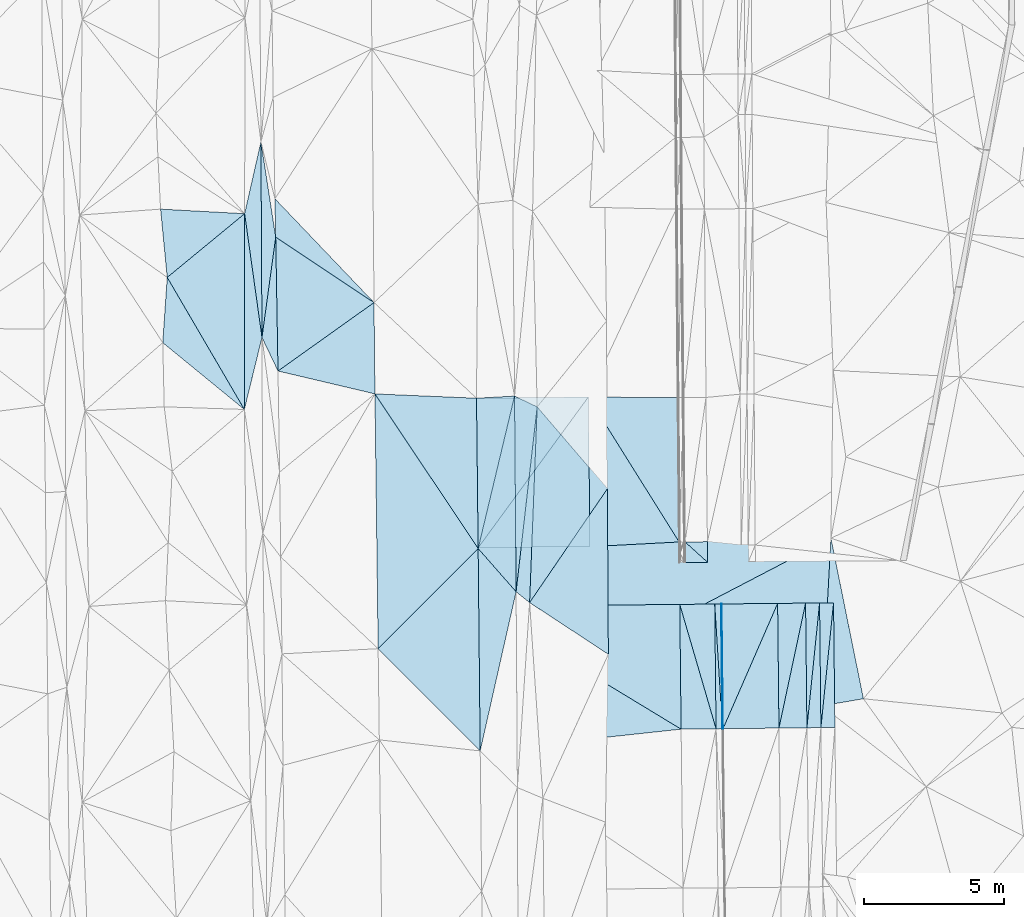
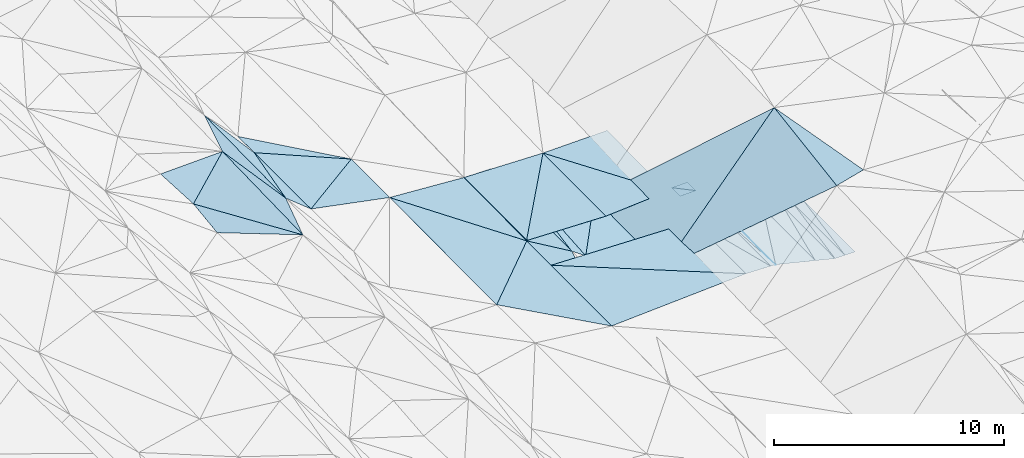
# One storey, part 36 of 275: 45 plates.
"""IFC2X3 building model written with IfcOpenShell, lengths in millimetres."""

from ifc_helpers import new_model, si_unit, frame, origin_with_axes, place, context, subcontext, project, spatial, polyline, outline, extrude, material, type_object, element, save


model = new_model("IFC2X3")

# Units and contexts
model_context = context("Model", 3, precision=1e-05, world=origin_with_axes())
body_context = subcontext(model_context, "Body", "Model", "MODEL_VIEW")
ifc_project = project(units=[si_unit("LENGTHUNIT", "METRE", prefix="MILLI"), si_unit("AREAUNIT", "SQUARE_METRE"), si_unit("VOLUMEUNIT", "CUBIC_METRE"), si_unit("MASSUNIT", "GRAM", prefix="KILO"), si_unit("TIMEUNIT", "SECOND"), si_unit("PLANEANGLEUNIT", "RADIAN"), si_unit("SOLIDANGLEUNIT", "STERADIAN"), si_unit("THERMODYNAMICTEMPERATUREUNIT", "DEGREE_CELSIUS"), si_unit("LUMINOUSINTENSITYUNIT", "LUMEN")], contexts=[model_context])

# Site, building, storey
site_placement = place(None, origin_with_axes())
site = spatial("IfcSite", under=ifc_project, at=site_placement, CompositionType="ELEMENT")
building_placement = place(site_placement, origin_with_axes())
building = spatial("IfcBuilding", under=site, at=building_placement, Name="Undefined", CompositionType="ELEMENT")
storey_placement = place(building_placement, origin_with_axes())
storey = spatial("IfcBuildingStorey", under=building, at=storey_placement, Name="Undefined", CompositionType="ELEMENT", Elevation=0.0)

# Plates
ifc_material = material()
plate_type_1 = type_object("IfcPlateType", PredefinedType="NOTDEFINED")
plate_1_placement = place(storey_placement, frame((-55777.1554334215, 17783.2295851217, 41273.1487418391), z_axis=(-0.0501446646772077, 0.0208601791780179, -0.998524093614707), x_axis=(-0.0106741270589884, 0.999713559361864, 0.021421069991057)))
element("IfcPlate", 1, at=plate_1_placement, inside=storey, type_object=plate_type_1, material=ifc_material, Name="00_PR", context=body_context, shape_type="SweptSolid", body=[
    extrude(outline(polyline([(0.0, 0.0), (4462.4755859375, -5.58065949007869e-09), (4462.4462890625, 20.0245208740234), (0.0, 0.0)])), frame((-8.85201319254618e-08, 2.18876761149539e-07, -0.5000001331573), z_axis=(0.0, 0.0, 1.0), x_axis=(1.0, 0.0, 0.0)), (0.0, 0.0, 1.0), 1.0),
])
plate_2_placement = place(storey_placement, frame((-55804.7899737754, 22244.6326134434, 41367.7397417833), z_axis=(-0.0501609440777703, 0.0208600609211892, -0.998523278420484), x_axis=(0.0106741250532589, -0.99971355781946, -0.0214211429738157)))
element("IfcPlate", 2, at=plate_2_placement, inside=storey, type_object=plate_type_1, material=ifc_material, Name="00_PR", context=body_context, shape_type="SweptSolid", body=[
    extrude(outline(polyline([(0.0, 0.0), (4462.4599609375, -2.99041857942939e-09), (4462.4462890625, 20.0245208740234), (0.0, 0.0)])), frame((-8.85201319254618e-08, 2.18876761149539e-07, -0.5000001331573), z_axis=(0.0, 0.0, 1.0), x_axis=(1.0, 0.0, 0.0)), (0.0, 0.0, 1.0), 1.0),
])
plate_type_2 = type_object("IfcPlateType", PredefinedType="NOTDEFINED")
plate_3_placement = place(storey_placement, frame((-72876.4648465357, 29201.440175099, 41922.5067376926), z_axis=(0.162034691991105, 0.0235866719560773, -0.986503131012459), x_axis=(0.00138285245792622, 0.999707884204713, 0.0241295250267475)))
element("IfcPlate", 3, at=plate_3_placement, inside=storey, type_object=plate_type_2, material=ifc_material, Name="00", context=body_context, shape_type="SweptSolid", body=[
    extrude(outline(polyline([(0.0, 0.0), (7003.86767578125, 1.18670868687332e-08), (2578.59887695313, 634.619445800781), (0.0, 0.0)])), frame((-8.85201319254618e-08, 2.18876761149539e-07, -0.5000001331573), z_axis=(0.0, 0.0, 1.0), x_axis=(1.0, 0.0, 0.0)), (0.0, 0.0, 1.0), 1.0),
])
plate_type_3 = type_object("IfcPlateType", PredefinedType="NOTDEFINED")
plate_4_placement = place(storey_placement, frame((-60573.8020393631, 29647.2975248427, 41682.6393767617), z_axis=(-0.0319265502433423, 0.0219599536153499, -0.999248945872234), x_axis=(-0.590092143941473, -0.807335138867878, 0.00111139900097563)))
element("IfcPlate", 4, at=plate_4_placement, inside=storey, type_object=plate_type_3, material=ifc_material, Name="00_PR", context=body_context, shape_type="SweptSolid", body=[
    extrude(outline(polyline([(0.0, 0.0), (6680.767578125, -8.60018189996481e-09), (2395.93823242188, 3206.45239257813), (0.0, 0.0)])), frame((-8.85201319254618e-08, 2.18876761149539e-07, -0.5000001331573), z_axis=(0.0, 0.0, 1.0), x_axis=(1.0, 0.0, 0.0)), (0.0, 0.0, 1.0), 1.0),
])
plate_type_4 = type_object("IfcPlateType", PredefinedType="NOTDEFINED")
plate_5_placement = place(storey_placement, frame((-64516.0709698577, 24253.6794883369, 41690.064400732), z_axis=(-0.032895759389629, 0.02266842670576, -0.999201687070666), x_axis=(0.590092143943861, 0.807335138866125, -0.00111139900671296)))
element("IfcPlate", 5, at=plate_5_placement, inside=storey, type_object=plate_type_4, material=ifc_material, Name="00_PR", context=body_context, shape_type="SweptSolid", body=[
    extrude(outline(polyline([(0.0, 0.0), (6680.767578125, -8.60018189996481e-09), (2393.00903320313, 3207.89916992188), (0.0, 0.0)])), frame((-8.85201319254618e-08, 2.18876761149539e-07, -0.5000001331573), z_axis=(0.0, 0.0, 1.0), x_axis=(1.0, 0.0, 0.0)), (0.0, 0.0, 1.0), 1.0),
])
plate_type_5 = type_object("IfcPlateType", PredefinedType="NOTDEFINED")
plate_6_placement = place(storey_placement, frame((-56317.310180276, 24471.5150313919, 41794.6452085543), z_axis=(0.0197854119140253, 0.0208739121605425, -0.999586323068952), x_axis=(0.00998879700031528, -0.999736259864483, -0.0206793289702882)))
element("IfcPlate", 6, at=plate_6_placement, inside=storey, type_object=plate_type_5, material=ifc_material, Name="00_PR", context=body_context, shape_type="SweptSolid", body=[
    extrude(outline(polyline([(0.0, 0.0), (735.226928710938, -3.92901711165905e-10), (0.282490730285645, 800.160034179688), (0.0, 0.0)])), frame((-8.85201319254618e-08, 2.18876761149539e-07, -0.5000001331573), z_axis=(0.0, 0.0, 1.0), x_axis=(1.0, 0.0, 0.0)), (0.0, 0.0, 1.0), 1.0),
])
plate_7_placement = place(storey_placement, frame((-56309.9661483693, 23736.4819831876, 41779.4412083081), z_axis=(0.0197829334125956, 0.0208711596541503, -0.999586429599904), x_axis=(-0.999749541560131, -0.0100505489961167, -0.0199960149825835)))
element("IfcPlate", 7, at=plate_7_placement, inside=storey, type_object=plate_type_5, material=ifc_material, Name="00_PR", context=body_context, shape_type="SweptSolid", body=[
    extrude(outline(polyline([(0.0, 0.0), (800.159423828125, 8.73114913702011e-11), (799.810791015625, 735.324523925781), (0.0, 0.0)])), frame((-8.85201319254618e-08, 2.18876761149539e-07, -0.5000001331573), z_axis=(0.0, 0.0, 1.0), x_axis=(1.0, 0.0, 0.0)), (0.0, 0.0, 1.0), 1.0),
])
plate_type_6 = type_object("IfcPlateType", PredefinedType="NOTDEFINED")
plate_8_placement = place(storey_placement, frame((-60573.771340355, 29647.2981410946, 41682.6393535976), z_axis=(0.0294745855623084, 0.0231916276288009, -0.999296451116413), x_axis=(0.999538032625305, -0.00809925297462628, 0.0292937439872152)))
element("IfcPlate", 8, at=plate_8_placement, inside=storey, type_object=plate_type_6, material=ifc_material, Name="00_PR", context=body_context, shape_type="SweptSolid", body=[
    extrude(outline(polyline([(0.0, 0.0), (3198.9765625, -1.10521796159446e-08), (3286.29663085938, 5160.751953125), (0.0, 0.0)])), frame((-8.85201319254618e-08, 2.18876761149539e-07, -0.5000001331573), z_axis=(0.0, 0.0, 1.0), x_axis=(1.0, 0.0, 0.0)), (0.0, 0.0, 1.0), 1.0),
])
plate_type_7 = type_object("IfcPlateType", PredefinedType="NOTDEFINED")
plate_9_placement = place(storey_placement, frame((-57327.2554332078, 24461.4869282185, 41658.044359245), z_axis=(0.0297168375314358, 0.0233432349976654, -0.999285746394381), x_axis=(-0.998147848622734, -0.0523987390032865, -0.0309070289849005)))
element("IfcPlate", 9, at=plate_9_placement, inside=storey, type_object=plate_type_7, material=ifc_material, Name="00_PR", context=body_context, shape_type="SweptSolid", body=[
    extrude(outline(polyline([(0.0, 0.0), (3194.904296875, 1.06083462014794e-08), (2968.0126953125, 5350.14111328125), (0.0, 0.0)])), frame((-8.85201319254618e-08, 2.18876761149539e-07, -0.5000001331573), z_axis=(0.0, 0.0, 1.0), x_axis=(1.0, 0.0, 0.0)), (0.0, 0.0, 1.0), 1.0),
])
plate_type_8 = type_object("IfcPlateType", PredefinedType="NOTDEFINED")
plate_10_placement = place(storey_placement, frame((-51804.970614998, 22285.1959415633, 40617.7121190453), z_axis=(-0.000237851747795639, 0.0214314280327073, -0.999770292276693), x_axis=(0.0106742570492596, -0.999713307722176, -0.0214327459657632)))
element("IfcPlate", 10, at=plate_10_placement, inside=storey, type_object=plate_type_8, material=ifc_material, Name="00_PR", context=body_context, shape_type="SweptSolid", body=[
    extrude(outline(polyline([(0.0, 0.0), (4459.3447265625, 2.65572452917695e-09), (4459.46142578125, 499.999694824219), (0.0, 0.0)])), frame((-8.85201319254618e-08, 2.18876761149539e-07, -0.5000001331573), z_axis=(0.0, 0.0, 1.0), x_axis=(1.0, 0.0, 0.0)), (0.0, 0.0, 1.0), 1.0),
])
plate_11_placement = place(storey_placement, frame((-52304.9448781681, 22280.1310432027, 40617.7141190329), z_axis=(-0.00023685420763401, 0.0214295615834027, -0.999770332521638), x_axis=(0.0106742880492719, -0.999713347630073, -0.0214308689724623)))
element("IfcPlate", 11, at=plate_11_placement, inside=storey, type_object=plate_type_8, material=ifc_material, Name="00_PR", context=body_context, shape_type="SweptSolid", body=[
    extrude(outline(polyline([(0.0, 0.0), (4459.73486328125, 3.15776560455561e-09), (4459.78271484375, 500.000152587891), (0.0, 0.0)])), frame((-8.85201319254618e-08, 2.18876761149539e-07, -0.5000001331573), z_axis=(0.0, 0.0, 1.0), x_axis=(1.0, 0.0, 0.0)), (0.0, 0.0, 1.0), 1.0),
])
plate_12_placement = place(storey_placement, frame((-52257.3403708549, 17821.6743357342, 40522.1381190825), z_axis=(-0.000221089482628541, 0.0214297299105289, -0.999770332524127), x_axis=(-0.0106742880482115, 0.999713347630049, 0.0214308689740677)))
element("IfcPlate", 12, at=plate_12_placement, inside=storey, type_object=plate_type_8, material=ifc_material, Name="00_PR", context=body_context, shape_type="SweptSolid", body=[
    extrude(outline(polyline([(0.0, 0.0), (4459.73486328125, 3.15776560455561e-09), (4459.46142578125, 499.999847412109), (0.0, 0.0)])), frame((-8.85201319254618e-08, 2.18876761149539e-07, -0.5000001331573), z_axis=(0.0, 0.0, 1.0), x_axis=(1.0, 0.0, 0.0)), (0.0, 0.0, 1.0), 1.0),
])
plate_13_placement = place(storey_placement, frame((-52757.3115064578, 17816.2882766866, 40522.1411188396), z_axis=(-0.000217341620207625, 0.0214275858204897, -0.99977037930143), x_axis=(-0.0106742930595841, 0.999713394392209, 0.0214286849919976)))
element("IfcPlate", 13, at=plate_13_placement, inside=storey, type_object=plate_type_8, material=ifc_material, Name="00_PR", context=body_context, shape_type="SweptSolid", body=[
    extrude(outline(polyline([(0.0, 0.0), (4460.14306640625, -5.78438630327582e-09), (4459.78271484375, 500.000152587891), (0.0, 0.0)])), frame((-8.85201319254618e-08, 2.18876761149539e-07, -0.5000001331573), z_axis=(0.0, 0.0, 1.0), x_axis=(1.0, 0.0, 0.0)), (0.0, 0.0, 1.0), 1.0),
])
plate_type_9 = type_object("IfcPlateType", PredefinedType="NOTDEFINED")
plate_14_placement = place(storey_placement, frame((-52805.0416228247, 22275.1514467781, 40617.7310385592), z_axis=(-0.242698624432495, 0.0181989258917549, -0.969931016513526), x_axis=(0.0106742930576428, -0.999713394392173, -0.0214286849946583)))
element("IfcPlate", 14, at=plate_14_placement, inside=storey, type_object=plate_type_9, material=ifc_material, Name="00_PR", context=body_context, shape_type="SweptSolid", body=[
    extrude(outline(polyline([(0.0, 0.0), (4460.14306640625, -5.78438630327582e-09), (4454.88134765625, 1030.76477050781), (0.0, 0.0)])), frame((-8.85201319254618e-08, 2.18876761149539e-07, -0.5000001331573), z_axis=(0.0, 0.0, 1.0), x_axis=(1.0, 0.0, 0.0)), (0.0, 0.0, 1.0), 1.0),
])
plate_type_10 = type_object("IfcPlateType", PredefinedType="NOTDEFINED")
plate_15_placement = place(storey_placement, frame((-55804.8862400831, 22244.6312789723, 41367.7540373688), z_axis=(-0.242692255592401, 0.0181917524070348, -0.969932744688947), x_axis=(0.970089052339762, 0.00997527605290578, -0.242544273068262)))
element("IfcPlate", 15, at=plate_15_placement, inside=storey, type_object=plate_type_10, material=ifc_material, Name="00_PR", context=body_context, shape_type="SweptSolid", body=[
    extrude(outline(polyline([(0.0, 0.0), (2061.5576171875, -6.18456397205591e-10), (24.8916435241699, 4462.390625), (0.0, 0.0)])), frame((-8.85201319254618e-08, 2.18876761149539e-07, -0.5000001331573), z_axis=(0.0, 0.0, 1.0), x_axis=(1.0, 0.0, 0.0)), (0.0, 0.0, 1.0), 1.0),
])
plate_16_placement = place(storey_placement, frame((-53804.9917380949, 22265.1958860816, 40867.7350383891), z_axis=(-0.242698747007133, 0.0181947316348315, -0.969931064530828), x_axis=(0.0106740970569017, -0.999713490145645, -0.0214243149909989)))
element("IfcPlate", 16, at=plate_16_placement, inside=storey, type_object=plate_type_10, material=ifc_material, Name="00_PR", context=body_context, shape_type="SweptSolid", body=[
    extrude(outline(polyline([(0.0, 0.0), (4460.95947265625, 4.22733137384057e-09), (4450.95947265625, 2061.52880859375), (0.0, 0.0)])), frame((-8.85201319254618e-08, 2.18876761149539e-07, -0.5000001331573), z_axis=(0.0, 0.0, 1.0), x_axis=(1.0, 0.0, 0.0)), (0.0, 0.0, 1.0), 1.0),
])
plate_type_11 = type_object("IfcPlateType", PredefinedType="NOTDEFINED")
plate_17_placement = place(storey_placement, frame((-53757.3750131241, 17805.5145443778, 40772.1620361945), z_axis=(-0.242681002786153, 0.018195016123679, -0.96993549902814), x_axis=(-0.0106740970567158, 0.999713490145698, 0.0214243149886176)))
element("IfcPlate", 17, at=plate_17_placement, inside=storey, type_object=plate_type_11, material=ifc_material, Name="00_PR", context=body_context, shape_type="SweptSolid", body=[
    extrude(outline(polyline([(0.0, 0.0), (4460.95947265625, 4.22733137384057e-09), (4454.88232421875, 1030.75915527344), (0.0, 0.0)])), frame((-8.85201319254618e-08, 2.18876761149539e-07, -0.5000001331573), z_axis=(0.0, 0.0, 1.0), x_axis=(1.0, 0.0, 0.0)), (0.0, 0.0, 1.0), 1.0),
])
plate_type_12 = type_object("IfcPlateType", PredefinedType="NOTDEFINED")
plate_18_placement = place(storey_placement, frame((-55777.1554334215, 17783.2295851217, 41273.1487418391), z_axis=(-0.0501436919474254, 0.0208601907028174, -0.998524142222773), x_axis=(-0.0621250970572903, 0.997780626059851, 0.0239644439792534)))
element("IfcPlate", 18, at=plate_18_placement, inside=storey, type_object=plate_type_12, material=ifc_material, Name="00_PR", context=body_context, shape_type="SweptSolid", body=[
    extrude(outline(polyline([(0.0, 0.0), (4468.74560546875, 7.88713805377483e-09), (4456.5458984375, 229.964385986328), (0.0, 0.0)])), frame((-8.85201319254618e-08, 2.18876761149539e-07, -0.5000001331573), z_axis=(0.0, 0.0, 1.0), x_axis=(1.0, 0.0, 0.0)), (0.0, 0.0, 1.0), 1.0),
])
plate_19_placement = place(storey_placement, frame((-56007.1419577483, 17780.6879738524, 41284.6487419182), z_axis=(-0.0501596127190712, 0.0208591811351555, -0.998523363679711), x_axis=(-0.0106741270589884, 0.999713559361864, 0.021421069991057)))
element("IfcPlate", 19, at=plate_19_placement, inside=storey, type_object=plate_type_12, material=ifc_material, Name="00_PR", context=body_context, shape_type="SweptSolid", body=[
    extrude(outline(polyline([(0.0, 0.0), (4462.6474609375, 6.38101482763886e-09), (-0.160347580909729, 230.287826538086), (0.0, 0.0)])), frame((-8.85201319254618e-08, 2.18876761149539e-07, -0.5000001331573), z_axis=(0.0, 0.0, 1.0), x_axis=(1.0, 0.0, 0.0)), (0.0, 0.0, 1.0), 1.0),
])
plate_type_13 = type_object("IfcPlateType", PredefinedType="NOTDEFINED")
plate_20_placement = place(storey_placement, frame((-56007.1327921838, 17780.6880795476, 41284.648367885), z_axis=(-0.0318285420601667, 0.021070928512991, -0.99927121437672), x_axis=(-0.279899349126619, 0.95958671622985, 0.0291494149805497)))
element("IfcPlate", 20, at=plate_20_placement, inside=storey, type_object=plate_type_13, material=ifc_material, Name="00_PR", context=body_context, shape_type="SweptSolid", body=[
    extrude(outline(polyline([(0.0, 0.0), (4635.83935546875, 2.7212081477046e-09), (4297.18994140625, 1203.90209960938), (0.0, 0.0)])), frame((-8.85201319254618e-08, 2.18876761149539e-07, -0.5000001331573), z_axis=(0.0, 0.0, 1.0), x_axis=(1.0, 0.0, 0.0)), (0.0, 0.0, 1.0), 1.0),
])
plate_type_14 = type_object("IfcPlateType", PredefinedType="NOTDEFINED")
plate_21_placement = place(storey_placement, frame((-64494.8697188954, 22156.5578941591, 41647.2373656865), z_axis=(-0.0318227816684431, 0.0209194607520966, -0.999274580247453), x_axis=(0.999449082754298, 0.0100943130575099, -0.0316170179727439)))
element("IfcPlate", 21, at=plate_21_placement, inside=storey, type_object=plate_type_14, material=ifc_material, Name="00_PR", context=body_context, shape_type="SweptSolid", body=[
    extrude(outline(polyline([(0.0, 0.0), (7194.1318359375, 2.06637196242809e-08), (7199.7080078125, 4463.5625), (0.0, 0.0)])), frame((-8.85201319254618e-08, 2.18876761149539e-07, -0.5000001331573), z_axis=(0.0, 0.0, 1.0), x_axis=(1.0, 0.0, 0.0)), (0.0, 0.0, 1.0), 1.0),
])
plate_type_15 = type_object("IfcPlateType", PredefinedType="NOTDEFINED")
plate_22_placement = place(storey_placement, frame((-57257.0567527238, 17766.8754753947, 41324.8463655012), z_axis=(-0.0323455602972673, 0.0200575562908744, -0.999275467108392), x_axis=(-0.993756122562119, -0.107462432012213, 0.0300099079692702)))
element("IfcPlate", 22, at=plate_22_placement, inside=storey, type_object=plate_type_15, material=ifc_material, Name="00_PR", context=body_context, shape_type="SweptSolid", body=[
    extrude(outline(polyline([(0.0, 0.0), (7230.7783203125, -1.73604348674417e-08), (6730.5703125, 5143.79296875), (0.0, 0.0)])), frame((-8.85201319254618e-08, 2.18876761149539e-07, -0.5000001331573), z_axis=(0.0, 0.0, 1.0), x_axis=(1.0, 0.0, 0.0)), (0.0, 0.0, 1.0), 1.0),
])
plate_type_16 = type_object("IfcPlateType", PredefinedType="NOTDEFINED")
plate_23_placement = place(storey_placement, frame((-57257.0567637822, 17766.875903244, 41324.846374686), z_axis=(-0.0323675739770536, 0.0209132745821325, -0.999257211683305), x_axis=(-0.0106741280628139, 0.9997168137473, 0.0212686459617179)))
element("IfcPlate", 23, at=plate_23_placement, inside=storey, type_object=plate_type_16, material=ifc_material, Name="00_PR", context=body_context, shape_type="SweptSolid", body=[
    extrude(outline(polyline([(0.0, 0.0), (4463.56591796875, 2.83034751191735e-09), (-0.388615489006042, 1250.64611816406), (0.0, 0.0)])), frame((-8.85201319254618e-08, 2.18876761149539e-07, -0.5000001331573), z_axis=(0.0, 0.0, 1.0), x_axis=(1.0, 0.0, 0.0)), (0.0, 0.0, 1.0), 1.0),
])
plate_type_17 = type_object("IfcPlateType", PredefinedType="NOTDEFINED")
plate_24_placement = place(storey_placement, frame((-68206.8982938697, 29758.1248953436, 41929.5003682819), z_axis=(-0.0320760603019315, 0.021958156539878, -0.999244197239532), x_axis=(0.998554724087374, -0.0424307064654024, -0.0329863328006586)))
element("IfcPlate", 24, at=plate_24_placement, inside=storey, type_object=plate_type_17, material=ifc_material, Name="00", context=body_context, shape_type="SweptSolid", body=[
    extrude(outline(polyline([(0.0, 0.0), (3637.87036132813, 7.42511474527419e-09), (3928.31494140625, 5369.17529296875), (0.0, 0.0)])), frame((-8.85201319254618e-08, 2.18876761149539e-07, -0.5000001331573), z_axis=(0.0, 0.0, 1.0), x_axis=(1.0, 0.0, 0.0)), (0.0, 0.0, 1.0), 1.0),
])
plate_type_18 = type_object("IfcPlateType", PredefinedType="NOTDEFINED")
plate_25_placement = place(storey_placement, frame((-71673.7237904427, 30576.1946679141, 42039.5004526709), z_axis=(-0.0369302499445179, 0.0223320081492676, -0.999068284979088), x_axis=(-0.430716952696215, 0.901765634886763, 0.0360783369539025)))
element("IfcPlate", 25, at=plate_25_placement, inside=storey, type_object=plate_type_18, material=ifc_material, Name="00", context=body_context, shape_type="SweptSolid", body=[
    extrude(outline(polyline([(0.0, 0.0), (1330.43823242188, -1.54250301420689e-09), (4354.677734375, 1989.11572265625), (0.0, 0.0)])), frame((-8.85201319254618e-08, 2.18876761149539e-07, -0.5000001331573), z_axis=(0.0, 0.0, 1.0), x_axis=(1.0, 0.0, 0.0)), (0.0, 0.0, 1.0), 1.0),
])
plate_type_19 = type_object("IfcPlateType", PredefinedType="NOTDEFINED")
plate_26_placement = place(storey_placement, frame((-72876.4868795494, 29201.4358245111, 41922.5035367772), z_axis=(0.117966994109999, 0.0148889536710046, -0.99290589048471), x_axis=(-0.771302019303008, 0.631142309561992, -0.0821740841132876)))
element("IfcPlate", 26, at=plate_26_placement, inside=storey, type_object=plate_type_19, material=ifc_material, Name="00", context=body_context, shape_type="SweptSolid", body=[
    extrude(outline(polyline([(0.0, 0.0), (3784.64819335938, 6.06814865022898e-09), (5129.92431640625, 1914.71899414063), (0.0, 0.0)])), frame((-8.85201319254618e-08, 2.18876761149539e-07, -0.5000001331573), z_axis=(0.0, 0.0, 1.0), x_axis=(1.0, 0.0, 0.0)), (0.0, 0.0, 1.0), 1.0),
])
plate_type_20 = type_object("IfcPlateType", PredefinedType="NOTDEFINED")
plate_27_placement = place(storey_placement, frame((-72246.7672121302, 31775.9383324764, 42087.5004981435), z_axis=(-0.0391358726774389, 0.0226324922192977, -0.998977554185137), x_axis=(-0.00536300667325262, 0.999724302452319, 0.022859511054435)))
element("IfcPlate", 27, at=plate_27_placement, inside=storey, type_object=plate_type_20, material=ifc_material, Name="00", context=body_context, shape_type="SweptSolid", body=[
    extrude(outline(polyline([(0.0, 0.0), (6999.27490234375, -2.38651409745216e-09), (3583.54833984375, 510.673553466797), (0.0, 0.0)])), frame((-8.85201319254618e-08, 2.18876761149539e-07, -0.5000001331573), z_axis=(0.0, 0.0, 1.0), x_axis=(1.0, 0.0, 0.0)), (0.0, 0.0, 1.0), 1.0),
])
plate_type_21 = type_object("IfcPlateType", PredefinedType="NOTDEFINED")
plate_28_placement = place(storey_placement, frame((-63213.6730228479, 29679.3794148561, 41764.5003886148), z_axis=(-0.0333884924312223, 0.021723874890444, -0.999206325957214), x_axis=(0.00791496853878586, -0.999726646622833, -0.0219996660269036)))
element("IfcPlate", 28, at=plate_28_placement, inside=storey, type_object=plate_type_21, material=ifc_material, Name="00", context=body_context, shape_type="SweptSolid", body=[
    extrude(outline(polyline([(0.0, 0.0), (7000.10595703125, 1.05210347101092e-08), (5440.83349609375, 1345.97985839844), (0.0, 0.0)])), frame((-8.85201319254618e-08, 2.18876761149539e-07, -0.5000001331573), z_axis=(0.0, 0.0, 1.0), x_axis=(1.0, 0.0, 0.0)), (0.0, 0.0, 1.0), 1.0),
])
plate_type_22 = type_object("IfcPlateType", PredefinedType="NOTDEFINED")
plate_29_placement = place(storey_placement, frame((-62404.336050705, 29292.6740134731, 41569.5294467821), z_axis=(-0.33657892224077, 0.032553010585577, -0.941092413424451), x_axis=(-0.0387480934458108, -0.999034599677351, -0.0206991280451361)))
element("IfcPlate", 29, at=plate_29_placement, inside=storey, type_object=plate_type_22, material=ifc_material, Name="00", context=body_context, shape_type="SweptSolid", body=[
    extrude(outline(polyline([(0.0, 0.0), (7005.1259765625, -7.62520357966423e-09), (6633.4697265625, 528.293090820313), (0.0, 0.0)])), frame((-8.85201319254618e-08, 2.18876761149539e-07, -0.5000001331573), z_axis=(0.0, 0.0, 1.0), x_axis=(1.0, 0.0, 0.0)), (0.0, 0.0, 1.0), 1.0),
])
plate_type_23 = type_object("IfcPlateType", PredefinedType="NOTDEFINED")
plate_30_placement = place(storey_placement, frame((-68240.0816263589, 33023.5529107429, 41999.5003337828), z_axis=(-0.0236439879045014, 0.028558390145933, -0.999312453734188), x_axis=(-0.832137629589241, 0.55343146873257, 0.0355045748898747)))
element("IfcPlate", 30, at=plate_30_placement, inside=storey, type_object=plate_type_23, material=ifc_material, Name="00", context=body_context, shape_type="SweptSolid", body=[
    extrude(outline(polyline([(0.0, 0.0), (4224.8076171875, 1.01063051261008e-08), (5011.61279296875, 1129.75122070313), (0.0, 0.0)])), frame((-8.85201319254618e-08, 2.18876761149539e-07, -0.5000001331573), z_axis=(0.0, 0.0, 1.0), x_axis=(1.0, 0.0, 0.0)), (0.0, 0.0, 1.0), 1.0),
])
plate_type_24 = type_object("IfcPlateType", PredefinedType="NOTDEFINED")
plate_31_placement = place(storey_placement, frame((-63158.3633475241, 22681.185747208, 41610.5129406021), z_axis=(-0.225265210919619, 0.0196522633714827, -0.974099262546542), x_axis=(-0.00791496854801373, 0.999726646623545, 0.0219996659912281)))
element("IfcPlate", 31, at=plate_31_placement, inside=storey, type_object=plate_type_24, material=ifc_material, Name="00", context=body_context, shape_type="SweptSolid", body=[
    extrude(outline(polyline([(0.0, 0.0), (7000.10595703125, 1.05210347101092e-08), (6602.80419921875, 827.64306640625), (0.0, 0.0)])), frame((-8.85201319254618e-08, 2.18876761149539e-07, -0.5000001331573), z_axis=(0.0, 0.0, 1.0), x_axis=(1.0, 0.0, 0.0)), (0.0, 0.0, 1.0), 1.0),
])
plate_type_25 = type_object("IfcPlateType", PredefinedType="NOTDEFINED")
plate_32_placement = place(storey_placement, frame((-72246.6672021399, 31775.9387232876, 42087.5066418046), z_axis=(0.160876606920193, 0.023424639692475, -0.986696510382561), x_axis=(-0.138710903568083, 0.990332512169981, 0.000894746008694923)))
element("IfcPlate", 32, at=plate_32_placement, inside=storey, type_object=plate_type_25, material=ifc_material, Name="00", context=body_context, shape_type="SweptSolid", body=[
    extrude(outline(polyline([(0.0, 0.0), (4470.5419921875, -5.71890268474817e-09), (6935.04833984375, 946.019165039063), (0.0, 0.0)])), frame((-8.85201319254618e-08, 2.18876761149539e-07, -0.5000001331573), z_axis=(0.0, 0.0, 1.0), x_axis=(1.0, 0.0, 0.0)), (0.0, 0.0, 1.0), 1.0),
])
plate_type_26 = type_object("IfcPlateType", PredefinedType="NOTDEFINED")
plate_33_placement = place(storey_placement, frame((-63213.6734609175, 29679.3795193368, 41764.5004056819), z_axis=(-0.034264782875885, 0.0219327318219378, -0.999172097253169), x_axis=(-0.232320842560443, -0.972547154484609, -0.0133812710867121)))
element("IfcPlate", 33, at=plate_33_placement, inside=storey, type_object=plate_type_26, material=ifc_material, Name="00", context=body_context, shape_type="SweptSolid", body=[
    extrude(outline(polyline([(0.0, 0.0), (5604.84912109375, 1.10740074887872e-08), (389.032958984375, 1306.7763671875), (0.0, 0.0)])), frame((-8.85201319254618e-08, 2.18876761149539e-07, -0.5000001331573), z_axis=(0.0, 0.0, 1.0), x_axis=(1.0, 0.0, 0.0)), (0.0, 0.0, 1.0), 1.0),
])
plate_type_27 = type_object("IfcPlateType", PredefinedType="NOTDEFINED")
plate_34_placement = place(storey_placement, frame((-59893.0521253703, 26365.0590303054, 41047.5070590177), z_axis=(-0.166054774915454, 0.022206699403476, -0.985866458618702), x_axis=(0.00566736655961306, -0.999708405339349, -0.0234730750038322)))
element("IfcPlate", 34, at=plate_34_placement, inside=storey, type_object=plate_type_27, material=ifc_material, Name="00", context=body_context, shape_type="SweptSolid", body=[
    extrude(outline(polyline([(0.0, 0.0), (5921.67822265625, 8.01082933321595e-09), (4044.94677734375, 2845.1044921875), (0.0, 0.0)])), frame((-8.85201319254618e-08, 2.18876761149539e-07, -0.5000001331573), z_axis=(0.0, 0.0, 1.0), x_axis=(1.0, 0.0, 0.0)), (0.0, 0.0, 1.0), 1.0),
])
plate_type_28 = type_object("IfcPlateType", PredefinedType="NOTDEFINED")
plate_35_placement = place(storey_placement, frame((-52223.7045836486, 18601.0869024228, 43729.5032250195), z_axis=(0.0967078786603512, 0.0595658911498384, -0.993528807240404), x_axis=(0.0541001413406437, 0.996417340910835, 0.0650050570271562)))
element("IfcPlate", 35, at=plate_35_placement, inside=storey, type_object=plate_type_28, material=ifc_material, Name="00", context=body_context, shape_type="SweptSolid", body=[
    extrude(outline(polyline([(0.0, 0.0), (6014.91650390625, 6.29370333626866e-09), (344.016906738281, 1477.76257324219), (0.0, 0.0)])), frame((-8.85201319254618e-08, 2.18876761149539e-07, -0.5000001331573), z_axis=(0.0, 0.0, 1.0), x_axis=(1.0, 0.0, 0.0)), (0.0, 0.0, 1.0), 1.0),
])
plate_type_29 = type_object("IfcPlateType", PredefinedType="NOTDEFINED")
plate_36_placement = place(storey_placement, frame((-64515.7953346491, 24228.3989152073, 41689.5003449215), z_axis=(-0.0315931135439454, 0.0203886129855482, -0.999292839780775), x_axis=(0.0100971765405648, -0.999734394322888, -0.0207168490306123)))
element("IfcPlate", 36, at=plate_36_placement, inside=storey, type_object=plate_type_29, material=ifc_material, Name="00", context=body_context, shape_type="SweptSolid", body=[
    extrude(outline(polyline([(0.0, 0.0), (7240.4833984375, -9.15315467864275e-09), (3544.33520507813, 3614.77368164063), (0.0, 0.0)])), frame((-8.85201319254618e-08, 2.18876761149539e-07, -0.5000001331573), z_axis=(0.0, 0.0, 1.0), x_axis=(1.0, 0.0, 0.0)), (0.0, 0.0, 1.0), 1.0),
])
plate_type_30 = type_object("IfcPlateType", PredefinedType="NOTDEFINED")
plate_37_placement = place(storey_placement, frame((-68240.083172836, 33023.5492148874, 41999.5002785826), z_axis=(-0.0267194820973921, 0.0211527108884024, -0.999419147354361), x_axis=(0.0101604596721452, -0.999718705707043, -0.0214306910454517)))
element("IfcPlate", 37, at=plate_37_placement, inside=storey, type_object=plate_type_30, material=ifc_material, Name="00", context=body_context, shape_type="SweptSolid", body=[
    extrude(outline(polyline([(0.0, 0.0), (3266.34350585938, 9.38598532229662e-09), (2410.92211914063, 3459.54541015625), (0.0, 0.0)])), frame((-8.85201319254618e-08, 2.18876761149539e-07, -0.5000001331573), z_axis=(0.0, 0.0, 1.0), x_axis=(1.0, 0.0, 0.0)), (0.0, 0.0, 1.0), 1.0),
])
plate_type_31 = type_object("IfcPlateType", PredefinedType="NOTDEFINED")
plate_38_placement = place(storey_placement, frame((-71673.7191608953, 30576.194744655, 42039.5003051058), z_axis=(-0.0276772210796454, 0.0224973235750521, -0.999363718505564), x_axis=(-0.0171251335988028, 0.999589316656287, 0.0229766800439297)))
element("IfcPlate", 38, at=plate_38_placement, inside=storey, type_object=plate_type_31, material=ifc_material, Name="00", context=body_context, shape_type="SweptSolid", body=[
    extrude(outline(polyline([(0.0, 0.0), (4787.462890625, -5.25324139744043e-09), (2386.62939453125, 3476.3486328125), (0.0, 0.0)])), frame((-8.85201319254618e-08, 2.18876761149539e-07, -0.5000001331573), z_axis=(0.0, 0.0, 1.0), x_axis=(1.0, 0.0, 0.0)), (0.0, 0.0, 1.0), 1.0),
])
plate_type_32 = type_object("IfcPlateType", PredefinedType="NOTDEFINED")
plate_39_placement = place(storey_placement, frame((-68206.8986208707, 29758.124677323, 41929.5003740957), z_axis=(-0.0327279795475036, 0.0215224939083049, -0.999232536305091), x_axis=(0.554819731594637, -0.831188098912435, -0.0360750559193891)))
element("IfcPlate", 39, at=plate_39_placement, inside=storey, type_object=plate_type_32, material=ifc_material, Name="00", context=body_context, shape_type="SweptSolid", body=[
    extrude(outline(polyline([(0.0, 0.0), (6652.79638671875, 6.25004759058356e-09), (7644.2744140625, 4964.4609375), (0.0, 0.0)])), frame((-8.85201319254618e-08, 2.18876761149539e-07, -0.5000001331573), z_axis=(0.0, 0.0, 1.0), x_axis=(1.0, 0.0, 0.0)), (0.0, 0.0, 1.0), 1.0),
])
plate_type_33 = type_object("IfcPlateType", PredefinedType="NOTDEFINED")
plate_40_placement = place(storey_placement, frame((-64515.7970156568, 24228.3988960982, 41689.500400351), z_axis=(-0.034950166877704, 0.0203524061279141, -0.999181797972734), x_axis=(0.659041715424146, -0.751127899658269, -0.0383522578964555)))
element("IfcPlate", 40, at=plate_40_placement, inside=storey, type_object=plate_type_33, material=ifc_material, Name="00", context=body_context, shape_type="SweptSolid", body=[
    extrude(outline(polyline([(0.0, 0.0), (2059.85278320313, 6.99947122484446e-09), (5491.01904296875, 4719.4609375), (0.0, 0.0)])), frame((-8.85201319254618e-08, 2.18876761149539e-07, -0.5000001331573), z_axis=(0.0, 0.0, 1.0), x_axis=(1.0, 0.0, 0.0)), (0.0, 0.0, 1.0), 1.0),
])
plate_type_34 = type_object("IfcPlateType", PredefinedType="NOTDEFINED")
plate_41_placement = place(storey_placement, frame((-62404.2542856717, 29292.6712923375, 41569.507723091), z_axis=(-0.173049066874765, 0.0271106137870965, -0.984540011921232), x_axis=(0.645181482287778, -0.752166551479195, -0.13411313786815)))
element("IfcPlate", 41, at=plate_41_placement, inside=storey, type_object=plate_type_34, material=ifc_material, Name="00", context=body_context, shape_type="SweptSolid", body=[
    extrude(outline(polyline([(0.0, 0.0), (3892.23608398438, 1.75350578501821e-09), (5108.25634765625, 4793.486328125), (0.0, 0.0)])), frame((-8.85201319254618e-08, 2.18876761149539e-07, -0.5000001331573), z_axis=(0.0, 0.0, 1.0), x_axis=(1.0, 0.0, 0.0)), (0.0, 0.0, 1.0), 1.0),
])
plate_type_35 = type_object("IfcPlateType", PredefinedType="NOTDEFINED")
plate_42_placement = place(storey_placement, frame((-72876.4794076592, 29201.4402456503, 41922.5045675998), z_axis=(0.132910284903613, 0.0237317306334536, -0.990843913604954), x_axis=(-0.503903281377634, 0.862483940584013, -0.0469354370548103)))
element("IfcPlate", 42, at=plate_42_placement, inside=storey, type_object=plate_type_35, material=ifc_material, Name="00", context=body_context, shape_type="SweptSolid", body=[
    extrude(outline(polyline([(0.0, 0.0), (5475.60693359375, 1.15542206913233e-08), (6026.14599609375, 3569.27490234375), (0.0, 0.0)])), frame((-8.85201319254618e-08, 2.18876761149539e-07, -0.5000001331573), z_axis=(0.0, 0.0, 1.0), x_axis=(1.0, 0.0, 0.0)), (0.0, 0.0, 1.0), 1.0),
])
plate_type_36 = type_object("IfcPlateType", PredefinedType="NOTDEFINED")
plate_43_placement = place(storey_placement, frame((-75635.6803601858, 33924.0934148405, 41665.5035132792), z_axis=(0.0834950203488076, 0.0841566842530449, -0.992948253471693), x_axis=(-0.0966550975473348, 0.992413347263118, 0.0759838159882013)))
element("IfcPlate", 43, at=plate_43_placement, inside=storey, type_object=plate_type_36, material=ifc_material, Name="00", context=body_context, shape_type="SweptSolid", body=[
    extrude(outline(polyline([(0.0, 0.0), (2461.05029296875, 8.2072801887989e-09), (2026.65173339844, 2989.23071289063), (0.0, 0.0)])), frame((-8.85201319254618e-08, 2.18876761149539e-07, -0.5000001331573), z_axis=(0.0, 0.0, 1.0), x_axis=(1.0, 0.0, 0.0)), (0.0, 0.0, 1.0), 1.0),
])
plate_type_37 = type_object("IfcPlateType", PredefinedType="NOTDEFINED")
plate_44_placement = place(storey_placement, frame((-59859.227127031, 20445.1083116318, 40908.534309615), z_axis=(0.363300521366795, 0.0239279277020644, -0.931364689823755), x_axis=(-0.00566736656101623, 0.999708405339352, 0.0234730750033579)))
element("IfcPlate", 44, at=plate_44_placement, inside=storey, type_object=plate_type_37, material=ifc_material, Name="00", context=body_context, shape_type="SweptSolid", body=[
    extrude(outline(polyline([(0.0, 0.0), (5921.67822265625, 8.01082933321595e-09), (4178.3955078125, 8570.4970703125), (0.0, 0.0)])), frame((-8.85201319254618e-08, 2.18876761149539e-07, -0.5000001331573), z_axis=(0.0, 0.0, 1.0), x_axis=(1.0, 0.0, 0.0)), (0.0, 0.0, 1.0), 1.0),
])
plate_type_38 = type_object("IfcPlateType", PredefinedType="NOTDEFINED")
plate_45_placement = place(storey_placement, frame((-51898.1676014046, 24594.4451720612, 44120.5330419868), z_axis=(0.355089688054186, 0.0416472931668749, -0.933904072380806), x_axis=(-0.0541001414259315, -0.996417340908092, -0.0650050569982142)))
element("IfcPlate", 45, at=plate_45_placement, inside=storey, type_object=plate_type_38, material=ifc_material, Name="00", context=body_context, shape_type="SweptSolid", body=[
    extrude(outline(polyline([(0.0, 0.0), (6014.91650390625, 6.29370333626866e-09), (4773.953125, 8253.591796875), (0.0, 0.0)])), frame((-8.85201319254618e-08, 2.18876761149539e-07, -0.5000001331573), z_axis=(0.0, 0.0, 1.0), x_axis=(1.0, 0.0, 0.0)), (0.0, 0.0, 1.0), 1.0),
])

save(model, "model.ifc")
